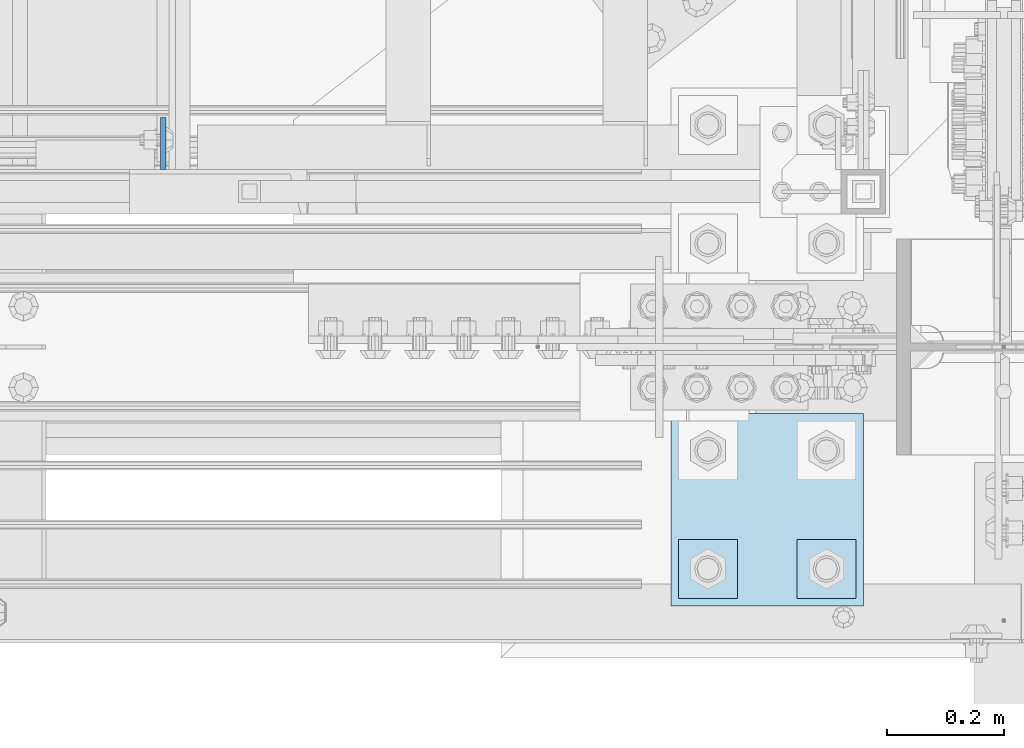
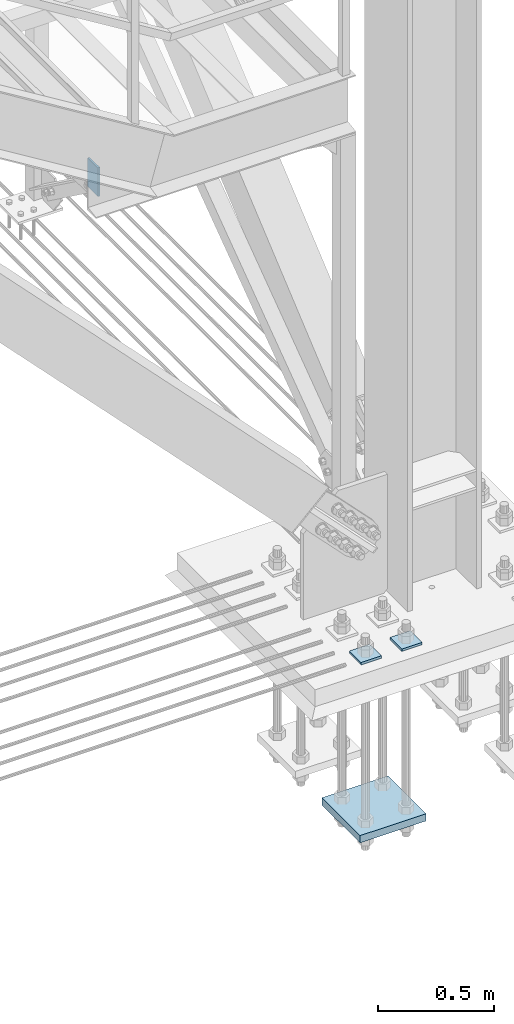
# One storey, part 3557 of 3843: 4 plates, 2 elements without a shape of their own.
"""IFC2X3 building model written with IfcOpenShell, lengths in millimetres."""

from ifc_helpers import new_model, si_unit, frame, origin_with_axes, place, context, subcontext, project, spatial, faceted_brep, material, type_object, element, aggregate, save


model = new_model("IFC2X3")

# Units and contexts
model_context = context("Model", 3, precision=1e-05, world=origin_with_axes())
body_context = subcontext(model_context, "Body", "Model", "MODEL_VIEW")
ifc_project = project(units=[si_unit("LENGTHUNIT", "METRE", prefix="MILLI"), si_unit("AREAUNIT", "SQUARE_METRE"), si_unit("VOLUMEUNIT", "CUBIC_METRE"), si_unit("MASSUNIT", "GRAM", prefix="KILO"), si_unit("TIMEUNIT", "SECOND"), si_unit("PLANEANGLEUNIT", "RADIAN"), si_unit("SOLIDANGLEUNIT", "STERADIAN"), si_unit("THERMODYNAMICTEMPERATUREUNIT", "DEGREE_CELSIUS"), si_unit("LUMINOUSINTENSITYUNIT", "LUMEN")], contexts=[model_context])

# Site, building, storey
site_placement = place(None, origin_with_axes())
site = spatial("IfcSite", under=ifc_project, at=site_placement, CompositionType="ELEMENT")
building_placement = place(site_placement, origin_with_axes())
building = spatial("IfcBuilding", under=site, at=building_placement, Name="Undefined", CompositionType="ELEMENT")
storey_placement = place(building_placement, origin_with_axes())
storey = spatial("IfcBuildingStorey", under=building, at=storey_placement, Name="Undefined", CompositionType="ELEMENT", Elevation=0.0)

# Assembly, plate
assembly_1_placement = place(storey_placement, origin_with_axes())
assembly_1 = element("IfcElementAssembly", 1, at=assembly_1_placement, inside=storey, Name="STAIR", AssemblyPlace="NOTDEFINED", PredefinedType="RIGID_FRAME")
ifc_material_1 = material(Name="STEEL/A36")
plate_type_1 = type_object("IfcPlateType", PredefinedType="NOTDEFINED")
plate_1_placement = place(assembly_1_placement, frame((84205.7625, 15303.4999999646, 32638.9999999993), z_axis=(0.0, 1.0, 0.0), x_axis=(0.0, 0.0, -1.0)))
plate_1 = element("IfcPlate", 2, at=plate_1_placement, type_object=plate_type_1, material=ifc_material_1, Name="PLATE", context=body_context, shape_type="Brep", body=[
    faceted_brep([(0.0, -4.76249999999709, 0.0), (0.0, -4.76249999999709, 88.9000015258789), (0.0, 4.76249999999709, 88.9000015258789), (0.0, 4.76249999999709, 0.0), (152.399993896484, -4.76249999999709, 88.9000015258789), (152.399993896484, 4.76249999999709, 88.9000015258789), (152.399993896484, -4.76249999999709, 0.0), (152.399993896484, 4.76249999999709, 0.0)], [[[0, 1, 2, 3]], [[1, 4, 5, 2]], [[4, 6, 7, 5]], [[6, 0, 3, 7]], [[5, 7, 3, 2]], [[6, 4, 1, 0]]]),
])
aggregate(assembly_1, [plate_1])

# Assembly, plates
assembly_2_placement = place(storey_placement, origin_with_axes())
assembly_2 = element("IfcElementAssembly", 3, at=assembly_2_placement, inside=storey, Name="TEMPLATE", AssemblyPlace="NOTDEFINED", PredefinedType="RIGID_FRAME")
ifc_material_2 = material(Name="STEEL/A572-50")
plate_type_2 = type_object("IfcPlateType", PredefinedType="NOTDEFINED")
plate_2_placement = place(assembly_2_placement, frame((85293.2, 14668.5, 30156.15), z_axis=(0.0, -1.0, 0.0), x_axis=(1.0, 0.0, 0.0)))
plate_2 = element("IfcPlate", 4, at=plate_2_placement, type_object=plate_type_2, material=ifc_material_2, Name="Washer Plate", context=body_context, shape_type="Brep", body=[
    faceted_brep([(0.0, -6.3499999046162, 0.0), (-1.67347025126219e-10, -6.35000000000582, 101.600000000151), (-1.67347025126219e-10, 6.35000000000582, 101.600000000151), (7.27595761418343e-12, 6.3499999046162, 0.0), (101.599998474121, -6.34999999999854, 101.599998474121), (101.599998474121, 6.34999999999854, 101.599998474121), (101.6, -6.34999999999854, 0.0), (101.6, 6.34999999999854, 0.0)], [[[0, 1, 2, 3]], [[1, 4, 5, 2]], [[4, 6, 7, 5]], [[6, 0, 3, 7]], [[5, 7, 3, 2]], [[6, 4, 1, 0]]]),
])
plate_3_placement = place(assembly_2_placement, frame((85090.0, 14668.5, 30156.15), z_axis=(0.0, -1.0, 0.0), x_axis=(1.0, 0.0, 0.0)))
plate_3 = element("IfcPlate", 5, at=plate_3_placement, type_object=plate_type_2, material=ifc_material_2, Name="Washer Plate", context=body_context, shape_type="Brep", body=[
    faceted_brep([(0.0, -6.3499999046162, 0.0), (-1.67347025126219e-10, -6.35000000000582, 101.600000000151), (-1.67347025126219e-10, 6.35000000000582, 101.600000000151), (7.27595761418343e-12, 6.3499999046162, 0.0), (101.599998474121, -6.34999999999854, 101.599998474121), (101.599998474121, 6.34999999999854, 101.599998474121), (101.6, -6.34999999999854, 0.0), (101.6, 6.34999999999854, 0.0)], [[[0, 1, 2, 3]], [[1, 4, 5, 2]], [[4, 6, 7, 5]], [[6, 0, 3, 7]], [[5, 7, 3, 2]], [[6, 4, 1, 0]]]),
])
plate_type_3 = type_object("IfcPlateType", PredefinedType="NOTDEFINED")
plate_4_placement = place(assembly_2_placement, frame((85407.5, 14884.3999969482, 29241.75), z_axis=(-1.0, 0.0, 0.0), x_axis=(0.0, -1.0, 0.0)))
plate_4 = element("IfcPlate", 6, at=plate_4_placement, type_object=plate_type_3, material=ifc_material_2, Name="PLATE", context=body_context, shape_type="Brep", body=[
    faceted_brep([(0.0, -19.0500000000029, 0.0), (0.0, -19.0499999999993, 330.200012207031), (0.0, 19.0499999999993, 330.200012207031), (0.0, 19.0500000000029, 0.0), (330.200012207031, -19.0499999999993, 330.200012207031), (330.200012207031, 19.0499999999993, 330.200012207031), (330.200012207031, -19.0499999999993, 0.0), (330.200012207031, 19.0499999999993, 0.0)], [[[0, 1, 2, 3]], [[1, 4, 5, 2]], [[4, 6, 7, 5]], [[6, 0, 3, 7]], [[5, 7, 3, 2]], [[6, 4, 1, 0]]]),
])
aggregate(assembly_2, [plate_4, plate_2, plate_3])

save(model, "model.ifc")
